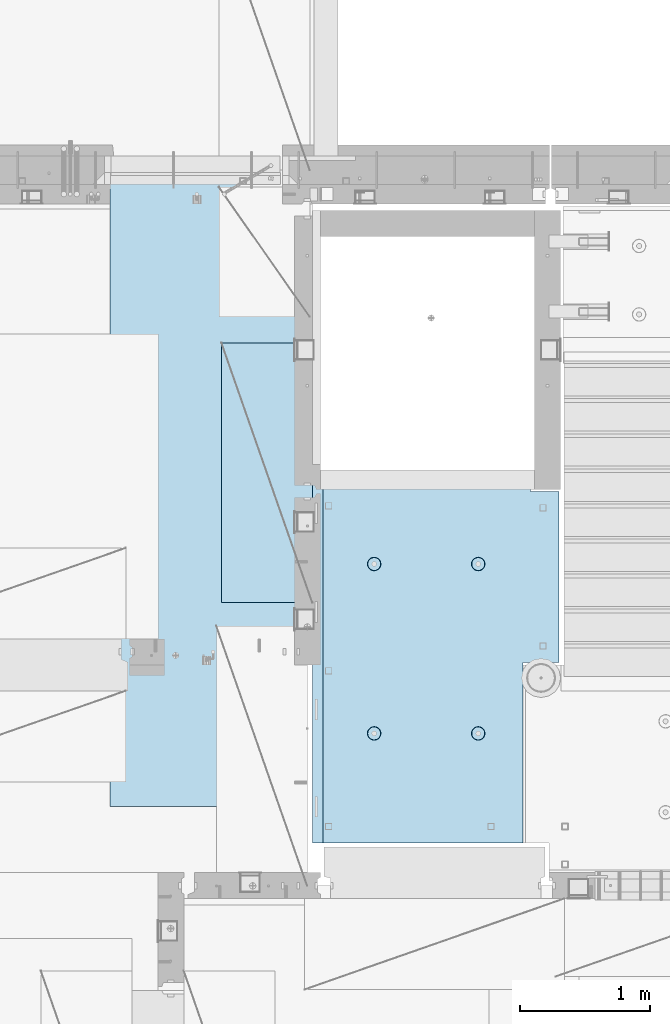
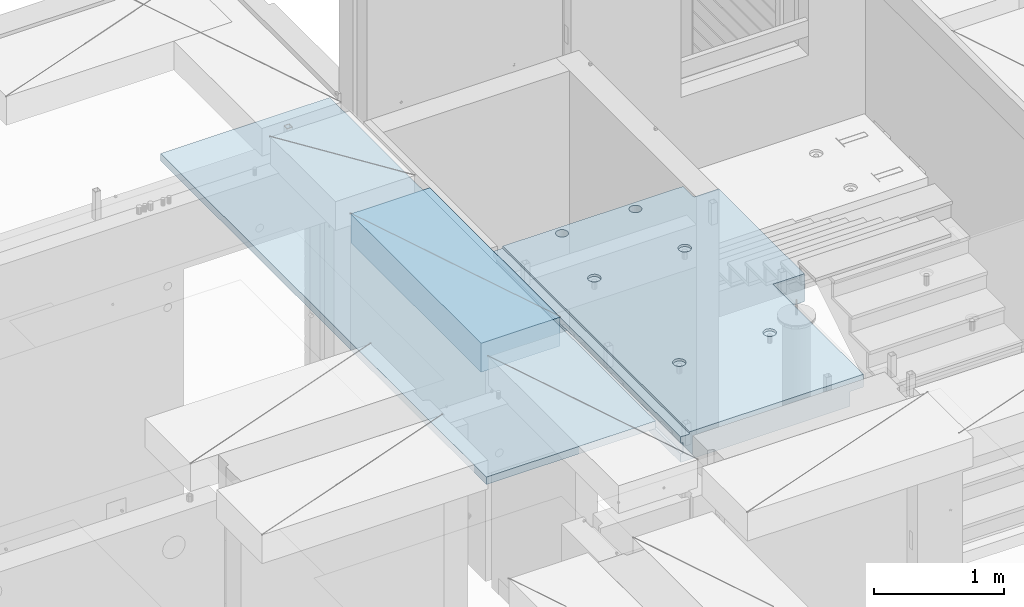
# One storey, part 186 of 325: 2 plates, 1 slab, 3 elements without a shape of their own.
"""IFC2X3 building model written with IfcOpenShell, lengths in millimetres."""

from ifc_helpers import new_model, si_unit, frame, origin_with_axes, place, context, subcontext, project, spatial, faceted_brep, material, type_object, element, aggregate, save


model = new_model("IFC2X3")

# Units and contexts
model_context = context("Model", 3, precision=1e-05, world=origin_with_axes())
body_context = subcontext(model_context, "Body", "Model", "MODEL_VIEW")
ifc_project = project(units=[si_unit("LENGTHUNIT", "METRE", prefix="MILLI"), si_unit("AREAUNIT", "SQUARE_METRE"), si_unit("VOLUMEUNIT", "CUBIC_METRE"), si_unit("MASSUNIT", "GRAM", prefix="KILO"), si_unit("TIMEUNIT", "SECOND"), si_unit("PLANEANGLEUNIT", "RADIAN"), si_unit("SOLIDANGLEUNIT", "STERADIAN"), si_unit("THERMODYNAMICTEMPERATUREUNIT", "DEGREE_CELSIUS"), si_unit("LUMINOUSINTENSITYUNIT", "LUMEN")], contexts=[model_context])

# Site, building, storey
site_placement = place(None, origin_with_axes())
site = spatial("IfcSite", under=ifc_project, at=site_placement, CompositionType="ELEMENT")
building_placement = place(site_placement, origin_with_axes())
building = spatial("IfcBuilding", under=site, at=building_placement, CompositionType="ELEMENT")
storey_placement = place(building_placement, origin_with_axes())
storey = spatial("IfcBuildingStorey", under=building, at=storey_placement, Name="1", CompositionType="ELEMENT", Elevation=0.0)

# Assembly, slab
assembly_1_placement = place(storey_placement, origin_with_axes())
assembly_1 = element("IfcElementAssembly", 1, at=assembly_1_placement, inside=storey, AssemblyPlace="NOTDEFINED", PredefinedType="REINFORCEMENT_UNIT")
ifc_material_1 = material(Name="CONCRETE/C25/30")
slab_type = type_object("IfcSlabType", PredefinedType="NOTDEFINED")
slab_placement = place(assembly_1_placement, frame((19370.0122708302, 15509.9992031236, 84620.0), z_axis=(-0.999999999999509, -9.91000000794397e-07, 0.0), x_axis=(-1.19799915409591e-06, 0.999999999999282, 0.0)))
slab = element("IfcSlab", 2, at=slab_placement, type_object=slab_type, material=ifc_material_1, PredefinedType="FLOOR", context=body_context, shape_type="Brep", body=[
    faceted_brep([(2774.54752338277, -130.0, 1012.45344539975), (2774.54752338277, 130.0, 1012.45344539975), (2760.60911899507, 130.0, 1019.55543819397), (2760.60911899507, -130.0, 1019.55543819397), (2749.54754514274, 130.0, 1030.61703854987), (2749.54754514274, -130.0, 1030.61703854987), (2742.44558574495, 130.0, 1044.5554599539), (2742.44558574495, -130.0, 1044.5554599539), (2739.99843006983, 130.0, 1060.00631260435), (2739.99843006983, -130.0, 1060.00631260435), (2742.44562276519, 130.0, 1075.45715939137), (2742.44562276519, -130.0, 1075.45715939137), (2749.54761555942, 130.0, 1089.39556377907), (2749.54761555942, -130.0, 1089.39556377907), (2760.60921591531, 130.0, 1100.45713763141), (2760.60921591531, -130.0, 1100.45713763141), (2774.54763731935, 130.0, 1107.55909702919), (2774.54763731935, -130.0, 1107.55909702919), (2789.9984899698, 130.0, 1110.00625270432), (2789.9984899698, -130.0, 1110.00625270432), (2805.44933675682, 130.0, 1107.55906000896), (2805.44933675682, -130.0, 1107.55906000896), (2819.38774114452, 130.0, 1100.45706721473), (2819.38774114452, -130.0, 1100.45706721473), (2830.44931499685, 130.0, 1089.39546685884), (2830.44931499685, -130.0, 1089.39546685884), (2837.55127439463, 130.0, 1075.4570454548), (2837.55127439463, -130.0, 1075.4570454548), (2839.99843006976, 130.0, 1060.00619280435), (2839.99843006976, -130.0, 1060.00619280435), (2837.5512373744, 130.0, 1044.55534601733), (2837.5512373744, -130.0, 1044.55534601733), (2830.44924458018, 130.0, 1030.61694162963), (2830.44924458018, -130.0, 1030.61694162963), (2819.38764422428, 130.0, 1019.55536777729), (2819.38764422428, -130.0, 1019.55536777729), (2805.44922282025, 130.0, 1012.45340837951), (2805.44922282025, -130.0, 1012.45340837951), (2789.9983701698, 130.0, 1010.00625270438), (2789.9983701698, -130.0, 1010.00625270438), (0.00273611420016096, 130.0, 1620.01171875), (0.00273611420016096, 50.0007877474418, 1620.01171875), (1649.99371079351, 50.0009873963572, 1620.01143803163), (1649.99371079351, 130.0, 1620.01143803163), (0.00270234311392414, 50.0007877474418, 1600.01636881603), (1649.99368684195, 50.0009873963427, 1600.0162648666), (1390.00354003907, -130.0, -1.24055077321827e-09), (0.0, -130.0, -3.63797880709171e-12), (0.0, -10.0, 0.0), (1390.00503210942, -10.0000000000582, -8.29459168016911e-10), (0.00020267313993827, -10.0000000000582, 119.999691808891), (1390.0049992294, -10.0000000000582, 120.000072670202), (1390.0049992294, 129.999999999942, 120.000072670202), (0.000202673141757259, 130.0, 119.999691808891), (1390.00354003907, 130.0, -1.24055077321827e-09), (1390.00305175782, -130.0, -279.993591308594), (1390.00350516116, 130.0, -19.9999273271205), (1390.00305175782, 130.0, -279.993591308594), (2704.99731446005, 130.0, -279.993808230734), (2704.99731446008, -130.0, -279.993645464809), (2704.99757802008, 130.0, -59.9936454649687), (2704.99757802008, -130.000000000015, -59.9936454649687), (2869.99708830242, -130.0, -59.9938431343799), (2869.99708830242, 130.0, -59.9938431343799), (2869.99538188219, 50.0011350165441, 1600.0161880065), (2869.99536132813, 50.0011350165441, 1620.01123046875), (2149.99371079323, 50.0010478963522, 1620.01135296499), (2149.99368684227, 50.0010478963377, 1600.0162333666), (2869.99536132813, -109.999999999985, 1620.01123046875), (0.00273611420016096, -109.999999999985, 1620.01171875), (0.0026009984267148, -109.999999999985, 1540.01171889739), (2869.99544356416, -109.999999999985, 1540.01180212718), (2869.99536132813, -49.9988649834559, 1620.01123046875), (0.00273611420016096, -49.9992122525582, 1620.01171875), (2869.99538188219, -49.9988649834559, 1600.01618800648), (0.00270234311210515, -49.9992122525582, 1600.01636881602), (2869.99544356416, -129.999999999985, 1540.01180212718), (2869.99536132813, 130.0, 1620.01123046875), (2149.99371079323, 130.0, 1620.01135296499), (2149.99345921271, 130.0, 1410.00825692148), (2149.99345921271, 30.0, 1410.00825692148), (2149.99368684227, 30.0, 1600.01623336659), (1649.99345921307, 130.0, 1410.00885592148), (1649.99345921307, 30.0, 1410.00885592148), (1649.99368684195, 30.0, 1600.01626486659), (0.0026009984267148, -130.0, 1540.01171889739), (858.080152798024, -110.0, 1097.45747495204), (872.018574202059, -110.0, 1104.55943434983), (883.080174557956, -110.0, 1115.62100820216), (890.182167352177, -110.0, 1129.55941258986), (892.62936004754, -110.0, 1145.01025937688), (890.182204372413, -110.0, 1160.46111202734), (883.08024497463, -110.0, 1174.39953343137), (872.018671122296, -110.0, 1185.46113378727), (858.080266734594, -110.0, 1192.56312658148), (842.629419947572, -110.0, 1195.01031927685), (827.178567297122, -110.0, 1192.56316360172), (813.240145893089, -110.0, 1185.46120420394), (802.178545537192, -110.0, 1174.3996303516), (795.076552742968, -110.0, 1160.46122596391), (792.629360047609, -110.0, 1145.01037917688), (795.076515722732, -110.0, 1129.55952652643), (802.178475120518, -110.0, 1115.62110512239), (813.240048972852, -110.0, 1104.5595047665), (827.178453360551, -110.0, 1097.45751197228), (842.629300147573, -110.0, 1095.01031927692), (858.782461559409, -130.0, 1095.29598202818), (842.629297424846, -130.0, 1092.73759200419), (873.354447572716, -130.0, 1102.72075776224), (884.918847944788, -130.0, 1114.28513042604), (892.343658593298, -130.0, 1128.85709864954), (894.902087320264, -130.0, 1145.01025665415), (892.34369729627, -130.0, 1161.16342078871), (884.918921562221, -130.0, 1175.73540680203), (873.354548898418, -130.0, 1187.29980717409), (858.782580674915, -130.0, 1194.72461782261), (842.629422670299, -130.0, 1197.28304654957), (826.476258535738, -130.0, 1194.72465652558), (811.90427252243, -130.0, 1187.29988079152), (800.339872150354, -130.0, 1175.73550812773), (792.915061501848, -130.0, 1161.16353990422), (790.356632774883, -130.0, 1145.01038189961), (792.915022798874, -130.0, 1128.85721776505), (800.339798532925, -130.0, 1114.28523175174), (811.904171196727, -130.0, 1102.72083137967), (826.476139420232, -130.0, 1095.29602073116), (858.08015281103, -110.0, 296.158841760913), (872.018574215066, -110.0, 303.2608011587), (883.080174570961, -110.0, 314.322375011034), (890.182167365187, -110.0, 328.26077939873), (892.629360060546, -110.0, 343.711626185755), (890.182204385423, -110.0, 359.162478836206), (883.080244987636, -110.0, 373.100900240239), (872.018671135302, -110.0, 384.16250059614), (858.0802667476, -110.0, 391.264493390358), (842.62941996058, -110.0, 393.711686085717), (827.178567310128, -110.0, 391.264530410594), (813.240145906095, -110.0, 384.16257101281), (802.178545550198, -110.0, 373.100997160473), (795.076552755974, -110.0, 359.162592772776), (792.629360060615, -110.0, 343.711745985755), (795.076515735738, -110.0, 328.2608933353), (802.178475133525, -110.0, 314.322471931268), (813.240048985859, -110.0, 303.26087157537), (827.178453373557, -110.0, 296.158878781149), (842.629300160579, -110.0, 293.71168608579), (858.782461572417, -130.0, 293.997348837052), (842.629297437852, -130.0, 291.438958813062), (873.354447585723, -130.0, 301.422124571109), (884.918847957797, -130.0, 312.98649723491), (892.343658606304, -130.0, 327.558465458413), (894.90208733327, -130.0, 343.711623463027), (892.343697309276, -130.0, 359.864787597588), (884.918921575227, -130.0, 374.436773610898), (873.354548911424, -130.0, 386.001173982968), (858.782580687921, -130.0, 393.425984631478), (842.629422683307, -130.0, 395.984413358441), (826.476258548744, -130.0, 393.426023334454), (811.904272535436, -130.0, 386.001247600398), (800.339872163362, -130.0, 374.4368749366), (792.915061514856, -130.0, 359.864906713094), (790.356632787889, -130.0, 343.711748708483), (792.915022811882, -130.0, 327.558584573919), (800.339798545931, -130.0, 312.986598560612), (811.904171209735, -130.0, 301.422198188538), (826.47613943324, -130.0, 293.997387540028), (2162.44895919675, -110.0, 1097.45754446905), (2176.38738060079, -110.0, 1104.55950386684), (2187.44898095669, -110.0, 1115.62107771917), (2194.55097375091, -110.0, 1129.55948210687), (2196.99816644627, -110.0, 1145.0103288939), (2194.55101077115, -110.0, 1160.46118154435), (2187.44905137336, -110.0, 1174.39960294838), (2176.38747752102, -110.0, 1185.46120330428), (2162.44907313332, -110.0, 1192.5631960985), (2146.9982263463, -110.0, 1195.01038879386), (2131.54737369585, -110.0, 1192.56323311873), (2117.60895229182, -110.0, 1185.46127372095), (2106.54735193592, -110.0, 1174.39969986862), (2099.4453591417, -110.0, 1160.46129548092), (2096.99816644634, -110.0, 1145.01044869389), (2099.44532212146, -110.0, 1129.55959604344), (2106.54728151925, -110.0, 1115.62117463941), (2117.60885537159, -110.0, 1104.55957428351), (2131.54725975928, -110.0, 1097.45758148929), (2146.9981065463, -110.0, 1095.01038879393), (2163.15126795814, -130.0, 1095.2960515452), (2146.99810382357, -130.0, 1092.73766152121), (2177.72325397145, -130.0, 1102.72082727925), (2189.28765434352, -130.0, 1114.28519994305), (2196.71246499203, -130.0, 1128.85716816655), (2199.27089371899, -130.0, 1145.01032617117), (2196.71250369501, -130.0, 1161.16349030573), (2189.28772796095, -130.0, 1175.73547631904), (2177.72335529715, -130.0, 1187.29987669111), (2163.15138707365, -130.0, 1194.72468733962), (2146.99822906903, -130.0, 1197.28311606658), (2130.84506493447, -130.0, 1194.72472604259), (2116.27307892116, -130.0, 1187.29995030854), (2104.70867854909, -130.0, 1175.73557764474), (2097.28386790058, -130.0, 1161.16360942123), (2094.72543917361, -130.0, 1145.01045141662), (2097.2838291976, -130.0, 1128.85728728206), (2104.70860493166, -130.0, 1114.28530126875), (2116.27297759546, -130.0, 1102.72090089668), (2130.84494581896, -130.0, 1095.29609024817), (2162.44895913772, -110.0, 296.158911320326), (2176.38738054176, -110.0, 303.260870718113), (2187.44898089765, -110.0, 314.322444570447), (2194.55097369188, -110.0, 328.260848958147), (2196.99816638724, -110.0, 343.711695745169), (2194.55101071211, -110.0, 359.162548395623), (2187.44905131433, -110.0, 373.100969799652), (2176.38747746199, -110.0, 384.162570155553), (2162.44907307429, -110.0, 391.264562949771), (2146.99822628727, -110.0, 393.711755645134), (2131.54737363682, -110.0, 391.264599970007), (2117.60895223279, -110.0, 384.162640572227), (2106.54735187689, -110.0, 373.10106671989), (2099.44535908267, -110.0, 359.162662332194), (2096.99816638731, -110.0, 343.711815545168), (2099.44532206243, -110.0, 328.260962894718), (2106.54728146021, -110.0, 314.322541490685), (2117.60885531255, -110.0, 303.260941134788), (2131.54725970025, -110.0, 296.158948340562), (2146.99810648727, -110.0, 293.711755645207), (2163.15126789911, -130.0, 293.997418396466), (2146.99810376454, -130.0, 291.439028372479), (2177.72325391241, -130.0, 301.422194130522), (2189.28765428449, -130.0, 312.986566794323), (2196.712464933, -130.0, 327.558535017826), (2199.27089365996, -130.0, 343.711693022444), (2196.71250363597, -130.0, 359.864857157001), (2189.28772790192, -130.0, 374.436843170311), (2177.72335523811, -130.0, 386.001243542381), (2163.15138701461, -130.0, 393.426054190892), (2146.99822901, -130.0, 395.984482917858), (2130.84506487544, -130.0, 393.426092893867), (2116.27307886213, -130.0, 386.001317159811), (2104.70867849006, -130.0, 374.436944496014), (2097.28386784155, -130.0, 359.864976272507), (2094.72543911458, -130.0, 343.711818267897), (2097.28382913857, -130.0, 327.558654133332), (2104.70860487263, -130.0, 312.986668120026), (2116.27297753642, -130.0, 301.422267747952), (2130.84494575993, -130.0, 293.997457099442), (2760.60834029508, -130.0, 369.555438194278), (2749.54676644274, -130.0, 380.617038550175), (2742.44480704495, -130.0, 394.555459954208), (2739.99765136983, -130.0, 410.006312604663), (2742.44484406519, -130.0, 425.457159391684), (2749.54683685942, -130.0, 439.395563779381), (2760.60843721531, -130.0, 450.457137631718), (2774.54685861935, -130.0, 457.559097029502), (2789.9977112698, -130.0, 460.006252704625), (2805.44855805682, -130.0, 457.559060009266), (2819.38696244451, -130.0, 450.457067215044), (2830.44853629686, -130.0, 439.395466859147), (2837.55049569464, -130.0, 425.457045455114), (2839.99765136976, -130.0, 410.006192804663), (2837.5504586744, -130.0, 394.555346017638), (2830.44846588018, -130.0, 380.616941629942), (2819.38686552428, -130.0, 369.555367777604), (2805.44844412025, -130.0, 362.453408379821), (2789.9975914698, -130.0, 360.006252704694), (2774.54674468278, -130.0, 362.453445400057), (2819.38686552428, 130.0, 369.555367777604), (2805.44844412025, 130.0, 362.453408379821), (2830.44846588018, 130.0, 380.616941629942), (2837.5504586744, 130.0, 394.555346017638), (2839.99765136976, 130.0, 410.006192804663), (2837.55049569464, 130.0, 425.457045455114), (2830.44853629686, 130.0, 439.395466859147), (2819.38696244451, 130.0, 450.457067215044), (2805.44855805682, 130.0, 457.559060009266), (2789.9977112698, 130.0, 460.006252704625), (2774.54685861935, 130.0, 457.559097029502), (2760.60843721531, 130.0, 450.457137631718), (2749.54683685942, 130.0, 439.395563779381), (2742.44484406519, 130.0, 425.457159391684), (2739.99765136983, 130.0, 410.006312604663), (2742.44480704495, 130.0, 394.555459954208), (2749.54676644274, 130.0, 380.617038550175), (2760.60834029508, 130.0, 369.555438194278), (2774.54674468278, 130.0, 362.453445400057), (2789.9975914698, 130.0, 360.006252704694)], [[[0, 1, 2, 3]], [[3, 2, 4, 5]], [[5, 4, 6, 7]], [[7, 6, 8, 9]], [[9, 8, 10, 11]], [[11, 10, 12, 13]], [[13, 12, 14, 15]], [[15, 14, 16, 17]], [[17, 16, 18, 19]], [[19, 18, 20, 21]], [[21, 20, 22, 23]], [[23, 22, 24, 25]], [[25, 24, 26, 27]], [[27, 26, 28, 29]], [[29, 28, 30, 31]], [[31, 30, 32, 33]], [[33, 32, 34, 35]], [[35, 34, 36, 37]], [[37, 36, 38, 39]], [[39, 38, 1, 0]], [[40, 41, 42, 43]], [[41, 44, 45, 42]], [[46, 47, 48, 49]], [[48, 50, 51, 49]], [[52, 51, 50, 53]], [[49, 51, 52, 54]], [[55, 46, 49, 54, 56, 57]], [[55, 57, 58, 59]], [[59, 58, 60, 61]], [[62, 61, 60, 63]], [[64, 65, 66, 67]], [[68, 69, 70, 71]], [[69, 68, 72, 73]], [[74, 75, 73, 72]], [[68, 71, 76, 62, 63, 77, 65, 64, 74, 72]], [[65, 77, 78, 66]], [[79, 80, 81, 67, 66, 78]], [[82, 83, 80, 79]], [[43, 42, 45, 84, 83, 82]], [[81, 80, 83, 84]], [[45, 44, 75, 74, 64, 67, 81, 84]], [[41, 40, 53, 50, 48, 47, 85, 70, 69, 73, 75, 44]], [[76, 71, 70, 85]], [[86, 87, 88, 89, 90, 91, 92, 93, 94, 95, 96, 97, 98, 99, 100, 101, 102, 103, 104, 105]], [[106, 86, 105, 107]], [[108, 87, 86, 106]], [[109, 88, 87, 108]], [[110, 89, 88, 109]], [[111, 90, 89, 110]], [[112, 91, 90, 111]], [[113, 92, 91, 112]], [[114, 93, 92, 113]], [[115, 94, 93, 114]], [[116, 95, 94, 115]], [[117, 96, 95, 116]], [[118, 97, 96, 117]], [[119, 98, 97, 118]], [[120, 99, 98, 119]], [[121, 100, 99, 120]], [[122, 101, 100, 121]], [[123, 102, 101, 122]], [[124, 103, 102, 123]], [[125, 104, 103, 124]], [[107, 105, 104, 125]], [[126, 127, 128, 129, 130, 131, 132, 133, 134, 135, 136, 137, 138, 139, 140, 141, 142, 143, 144, 145]], [[146, 126, 145, 147]], [[148, 127, 126, 146]], [[149, 128, 127, 148]], [[150, 129, 128, 149]], [[151, 130, 129, 150]], [[152, 131, 130, 151]], [[153, 132, 131, 152]], [[154, 133, 132, 153]], [[155, 134, 133, 154]], [[156, 135, 134, 155]], [[157, 136, 135, 156]], [[158, 137, 136, 157]], [[159, 138, 137, 158]], [[160, 139, 138, 159]], [[161, 140, 139, 160]], [[162, 141, 140, 161]], [[163, 142, 141, 162]], [[164, 143, 142, 163]], [[165, 144, 143, 164]], [[147, 145, 144, 165]], [[166, 167, 168, 169, 170, 171, 172, 173, 174, 175, 176, 177, 178, 179, 180, 181, 182, 183, 184, 185]], [[186, 166, 185, 187]], [[188, 167, 166, 186]], [[189, 168, 167, 188]], [[190, 169, 168, 189]], [[191, 170, 169, 190]], [[192, 171, 170, 191]], [[193, 172, 171, 192]], [[194, 173, 172, 193]], [[195, 174, 173, 194]], [[196, 175, 174, 195]], [[197, 176, 175, 196]], [[198, 177, 176, 197]], [[199, 178, 177, 198]], [[200, 179, 178, 199]], [[201, 180, 179, 200]], [[202, 181, 180, 201]], [[203, 182, 181, 202]], [[204, 183, 182, 203]], [[205, 184, 183, 204]], [[187, 185, 184, 205]], [[206, 207, 208, 209, 210, 211, 212, 213, 214, 215, 216, 217, 218, 219, 220, 221, 222, 223, 224, 225]], [[226, 206, 225, 227]], [[228, 207, 206, 226]], [[229, 208, 207, 228]], [[230, 209, 208, 229]], [[231, 210, 209, 230]], [[232, 211, 210, 231]], [[233, 212, 211, 232]], [[234, 213, 212, 233]], [[235, 214, 213, 234]], [[236, 215, 214, 235]], [[237, 216, 215, 236]], [[238, 217, 216, 237]], [[239, 218, 217, 238]], [[240, 219, 218, 239]], [[241, 220, 219, 240]], [[242, 221, 220, 241]], [[243, 222, 221, 242]], [[244, 223, 222, 243]], [[245, 224, 223, 244]], [[227, 225, 224, 245]], [[47, 46, 55, 59, 61, 62, 76, 85], [3, 5, 7, 9, 11, 13, 15, 17, 19, 21, 23, 25, 27, 29, 31, 33, 35, 37, 39, 0], [246, 247, 248, 249, 250, 251, 252, 253, 254, 255, 256, 257, 258, 259, 260, 261, 262, 263, 264, 265], [244, 243, 242, 241, 240, 239, 238, 237, 236, 235, 234, 233, 232, 231, 230, 229, 228, 226, 227, 245], [204, 203, 202, 201, 200, 199, 198, 197, 196, 195, 194, 193, 192, 191, 190, 189, 188, 186, 187, 205], [164, 163, 162, 161, 160, 159, 158, 157, 156, 155, 154, 153, 152, 151, 150, 149, 148, 146, 147, 165], [124, 123, 122, 121, 120, 119, 118, 117, 116, 115, 114, 113, 112, 111, 110, 109, 108, 106, 107, 125]], [[262, 266, 267, 263]], [[261, 268, 266, 262]], [[260, 269, 268, 261]], [[259, 270, 269, 260]], [[258, 271, 270, 259]], [[257, 272, 271, 258]], [[256, 273, 272, 257]], [[255, 274, 273, 256]], [[254, 275, 274, 255]], [[253, 276, 275, 254]], [[252, 277, 276, 253]], [[251, 278, 277, 252]], [[250, 279, 278, 251]], [[249, 280, 279, 250]], [[248, 281, 280, 249]], [[247, 282, 281, 248]], [[246, 283, 282, 247]], [[265, 284, 283, 246]], [[264, 285, 284, 265]], [[263, 267, 285, 264]], [[77, 63, 60, 58, 57, 56, 54, 52, 53, 40, 43, 82, 79, 78], [34, 32, 30, 28, 26, 24, 22, 20, 18, 16, 14, 12, 10, 8, 6, 4, 2, 1, 38, 36], [266, 268, 269, 270, 271, 272, 273, 274, 275, 276, 277, 278, 279, 280, 281, 282, 283, 284, 285, 267]]]),
])
aggregate(assembly_1, [slab])

# Assembly, plate
assembly_2_placement = place(storey_placement, origin_with_axes())
assembly_2 = element("IfcElementAssembly", 3, at=assembly_2_placement, inside=storey, Name="Steel Assembly", AssemblyPlace="NOTDEFINED", PredefinedType="NOTDEFINED")
ifc_material_2 = material()
plate_type_1 = type_object("IfcPlateType", PredefinedType="NOTDEFINED")
plate_1_placement = place(assembly_2_placement, frame((17690.0000122641, 20790.0, 84695.1000003815), z_axis=(0.0, -1.0, 0.0), x_axis=(-1.0, 3.00000001838171e-08, 0.0)))
plate_1 = element("IfcPlate", 4, at=plate_1_placement, type_object=plate_type_1, material=ifc_material_2, context=body_context, shape_type="Brep", body=[
    faceted_brep([(0.0, -35.0, 0.0), (0.0, -35.0, 5000.0), (0.0, 35.0, 5000.0), (0.0, 35.0, 0.0), (1499.99951171875, -35.0, 5000.0), (1499.99951171875, 35.0, 5000.0), (1500.0, -35.0, 0.0), (1500.0, 35.0, 0.0)], [[[0, 1, 2, 3]], [[1, 4, 5, 2]], [[4, 6, 7, 5]], [[6, 0, 3, 7]], [[5, 7, 3, 2]], [[6, 4, 1, 0]]]),
])
aggregate(assembly_2, [plate_1])

assembly_3_placement = place(storey_placement, origin_with_axes())
assembly_3 = element("IfcElementAssembly", 5, at=assembly_3_placement, inside=storey, Name="Steel Assembly", AssemblyPlace="NOTDEFINED", PredefinedType="NOTDEFINED")
plate_type_2 = type_object("IfcPlateType", PredefinedType="NOTDEFINED")
plate_2_placement = place(assembly_3_placement, frame((17750.0001220703, 17360.0, 84595.3), z_axis=(-1.0, 3.00000001838171e-08, 0.0), x_axis=(0.0, 1.0, 0.0)))
plate_2 = element("IfcPlate", 6, at=plate_2_placement, type_object=plate_type_2, material=ifc_material_2, Name="RE1", context=body_context, shape_type="Brep", body=[
    faceted_brep([(1.81898940354586e-12, -135.0, 1.81898940354586e-12), (0.0, -135.0, 699.999999999996), (0.0, 135.0, 699.999999999996), (1.81898940354586e-12, 135.0, 1.81898940354586e-12), (1999.99951171875, -135.0, 699.999999999993), (1999.99951171875, 135.0, 699.999999999993), (2000.0, -135.0, -3.63797880709171e-12), (2000.0, 135.0, -3.63797880709171e-12)], [[[0, 1, 2, 3]], [[1, 4, 5, 2]], [[4, 6, 7, 5]], [[6, 0, 3, 7]], [[5, 7, 3, 2]], [[6, 4, 1, 0]]]),
])
aggregate(assembly_3, [plate_2])

save(model, "model.ifc")
